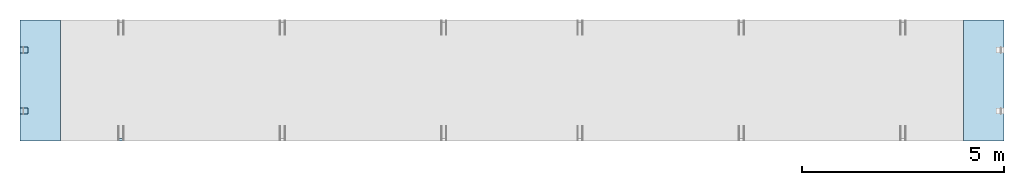
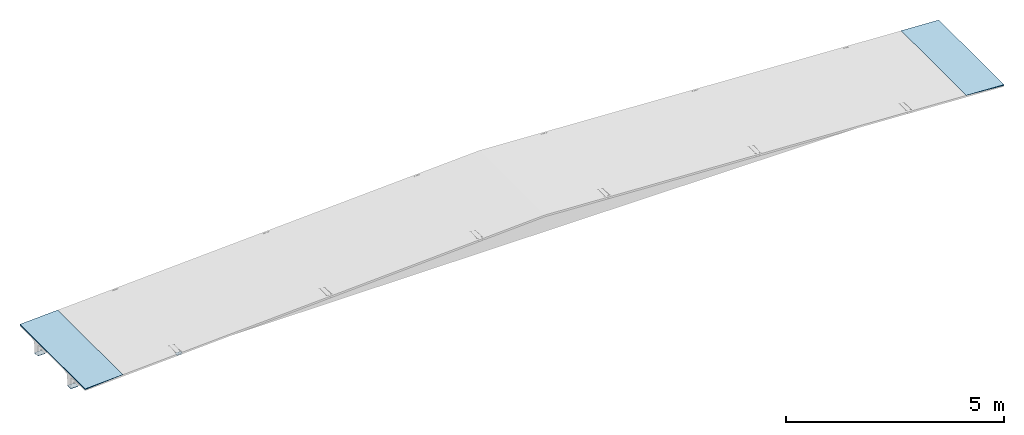
# One storey, part 3 of 8: 3 plates, 2 slabs.
"""IFC2X3 building model written with IfcOpenShell, lengths in millimetres."""

from ifc_helpers import new_model, si_unit, frame, origin_with_axes, place, context, subcontext, project, spatial, polyline, outline, extrude, material, layer, layer_set, layer_usage, type_object, element, save


model = new_model("IFC2X3")

# Units and contexts
model_context = context("Model", 3, precision=1e-05, world=origin_with_axes())
body_context = subcontext(model_context, "Body", "Model", "MODEL_VIEW")
ifc_project = project(units=[si_unit("LENGTHUNIT", "METRE", prefix="MILLI"), si_unit("AREAUNIT", "SQUARE_METRE"), si_unit("VOLUMEUNIT", "CUBIC_METRE"), si_unit("MASSUNIT", "GRAM", prefix="KILO"), si_unit("TIMEUNIT", "SECOND"), si_unit("PLANEANGLEUNIT", "RADIAN"), si_unit("SOLIDANGLEUNIT", "STERADIAN"), si_unit("THERMODYNAMICTEMPERATUREUNIT", "DEGREE_CELSIUS"), si_unit("LUMINOUSINTENSITYUNIT", "LUMEN")], contexts=[model_context])

# Site, building, storey
site_placement = place(None, origin_with_axes())
site = spatial("IfcSite", under=ifc_project, at=site_placement, CompositionType="ELEMENT")
building_placement = place(site_placement, origin_with_axes())
building = spatial("IfcBuilding", under=site, at=building_placement, Name="Undefined", CompositionType="ELEMENT")
storey_placement = place(building_placement, origin_with_axes())
storey = spatial("IfcBuildingStorey", under=building, at=storey_placement, Name="Undefined", CompositionType="ELEMENT", Elevation=0.0)

# Plates
ifc_material_1 = material(Name="STEEL/Steel_Undefined")
plate_type_1 = type_object("IfcPlateType", PredefinedType="NOTDEFINED")
plate_placement = place(storey_placement, frame((2496.88380513223, -1442.0, 516.09419025668), z_axis=(0.998752344077785, 1.34027108925072e-08, 0.0499375129449784), x_axis=(0.0269640012892069, -0.841694140243242, -0.539280925784202)))
element("IfcPlate", 1, at=plate_placement, inside=storey, type_object=plate_type_1, material=ifc_material_1, Name="TR39", context=body_context, shape_type="SweptSolid", body=[
    extrude(outline(polyline([(0.0, 0.0), (62.9682464599334, -1.52340362546965e-11), (62.9682464599343, 6.00000000002069), (2.9967850423418e-10, 6.0), (0.0, 0.0)])), frame((1.1342662920022e-13, 5.20417042793042e-16, -75.0000000000005), z_axis=(0.0, 0.0, 1.0), x_axis=(1.0, 0.0, 0.0)), (0.0, 0.0, 1.0), 150.0),
])
ifc_material_2 = material()
plate_type_2 = type_object("IfcPlateType", PredefinedType="NOTDEFINED")
for number, where, z_axis, x_axis in (
    (2, (-2.8421709430404e-14, -831.0, -5.00000000000006), (0.0, 0.0, 1.0), (1.0, 0.0, 0.0)),
    (3, (1.4210854715202e-13, 681.0, -5.00000000000026), (0.0, 0.0, 1.0), (1.0, 0.0, 0.0)),
):
    element("IfcPlate", number, at=place(storey_placement, frame(where, z_axis=z_axis, x_axis=x_axis)), inside=storey, type_object=plate_type_2, material=ifc_material_2, context=body_context, shape_type="SweptSolid", body=[
        extrude(outline(polyline([(0.0, 0.0), (200.0, 0.0), (200.0, 150.0), (2.8421709430404e-14, 150.0), (0.0, 0.0)])), frame((0.0, 0.0, -5.0), z_axis=(0.0, 0.0, 1.0), x_axis=(1.0, 0.0, 0.0)), (0.0, 0.0, 1.0), 10.0),
    ])

# Slabs
ifc_material_3 = material(Name="CONCRETE/Concrete_Undefined")
ifc_layer = layer(ifc_material_3, 2990.0)
ifc_layer_set = layer_set([ifc_layer], Name="Floor: Insitu CONCRETE/Concrete_Undefined")
ifc_layer_usage_1 = layer_usage(ifc_layer_set, "AXIS3", "POSITIVE", -1495.0)
slab_type = type_object("IfcSlabType", PredefinedType="NOTDEFINED")
slab_1_placement = place(storey_placement, frame((5.27828387121526e-14, -3.27270430338636e-13, 391.24999999997), z_axis=(0.0, -1.0, -1.64007595148417e-13), x_axis=(0.0, 0.0, -1.0)))
element("IfcSlab", 4, at=slab_1_placement, inside=storey, type_object=slab_type, material=ifc_layer_usage_1, PredefinedType="FLOOR", context=body_context, shape_type="SweptSolid", body=[
    extrude(outline(polyline([(0.0, 0.0), (25.0, 0.0), (-50.0, 1000.0), (0.0, 0.0)])), frame((0.0, 0.0, -1495.0), z_axis=(0.0, 0.0, 1.0), x_axis=(1.0, 0.0, 0.0)), (0.0, 0.0, 1.0), 2990.0),
])
ifc_layer_usage_2 = layer_usage(ifc_layer_set, "AXIS3", "POSITIVE", -1495.0)
slab_2_placement = place(storey_placement, frame((24350.0, -3.27270430338636e-13, 391.25), z_axis=(0.0, 1.0, 0.0), x_axis=(0.0, 0.0, -1.0)))
element("IfcSlab", 5, at=slab_2_placement, inside=storey, type_object=slab_type, material=ifc_layer_usage_2, PredefinedType="FLOOR", context=body_context, shape_type="SweptSolid", body=[
    extrude(outline(polyline([(0.0, 0.0), (25.0, 0.0), (-50.0, 1000.0), (0.0, 0.0)])), frame((0.0, 0.0, -1495.0), z_axis=(0.0, 0.0, 1.0), x_axis=(1.0, 0.0, 0.0)), (0.0, 0.0, 1.0), 2990.0),
])

save(model, "model.ifc")
